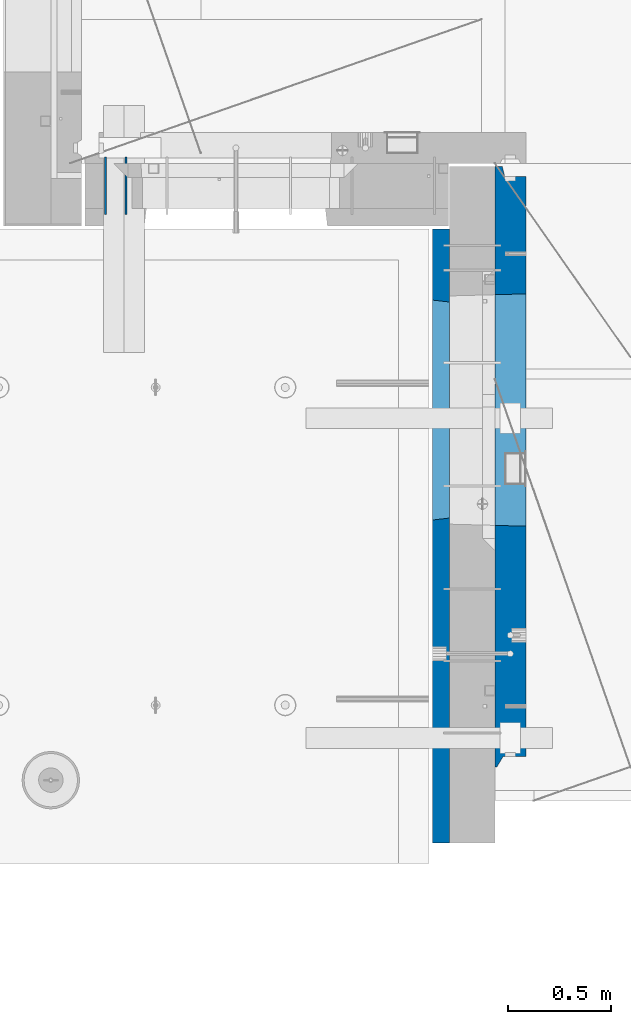
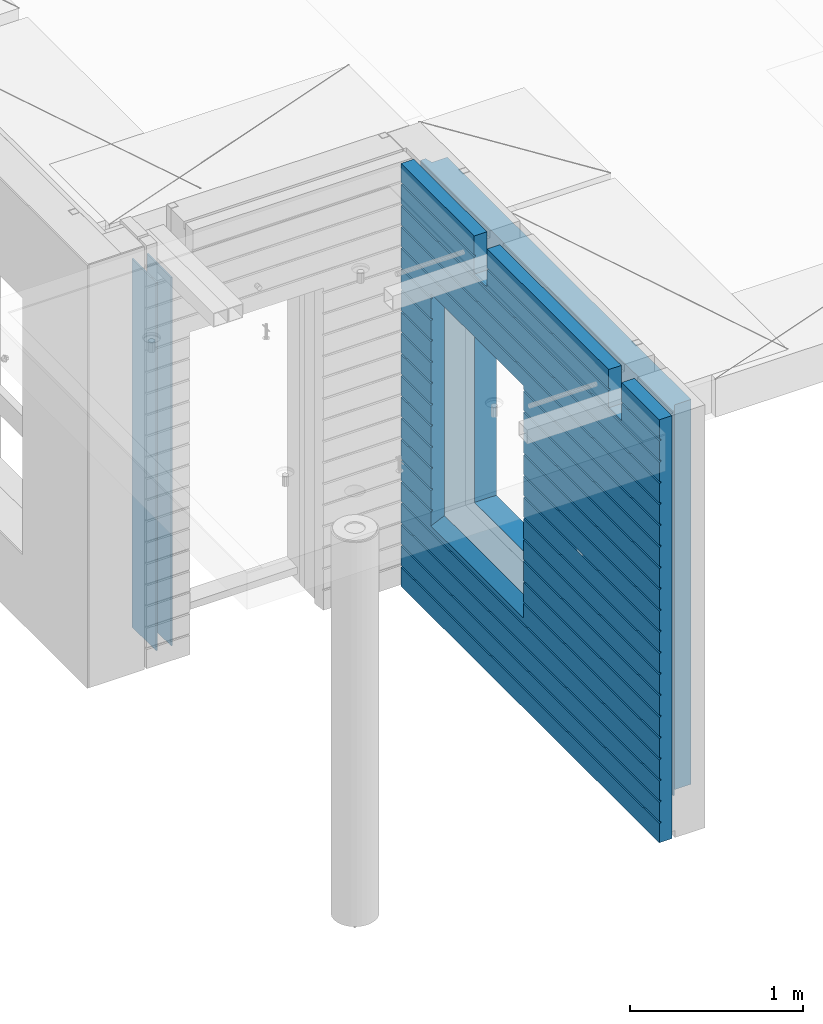
# One storey, part 193 of 309: 4 walls, 2 elements without a shape of their own.
"""IFC2X3 building model written with IfcOpenShell, lengths in millimetres."""

from ifc_helpers import new_model, si_unit, frame, origin_with_axes, place, context, subcontext, project, spatial, faceted_brep, material, type_object, element, aggregate, save


model = new_model("IFC2X3")

# Units and contexts
model_context = context("Model", 3, precision=1e-05, world=origin_with_axes())
body_context = subcontext(model_context, "Body", "Model", "MODEL_VIEW")
ifc_project = project(units=[si_unit("LENGTHUNIT", "METRE", prefix="MILLI"), si_unit("AREAUNIT", "SQUARE_METRE"), si_unit("VOLUMEUNIT", "CUBIC_METRE"), si_unit("MASSUNIT", "GRAM", prefix="KILO"), si_unit("TIMEUNIT", "SECOND"), si_unit("PLANEANGLEUNIT", "RADIAN"), si_unit("SOLIDANGLEUNIT", "STERADIAN"), si_unit("THERMODYNAMICTEMPERATUREUNIT", "DEGREE_CELSIUS"), si_unit("LUMINOUSINTENSITYUNIT", "LUMEN")], contexts=[model_context])

# Site, building, storey
site_placement = place(None, origin_with_axes())
site = spatial("IfcSite", under=ifc_project, at=site_placement, CompositionType="ELEMENT")
building_placement = place(site_placement, origin_with_axes())
building = spatial("IfcBuilding", under=site, at=building_placement, CompositionType="ELEMENT")
storey_placement = place(building_placement, origin_with_axes())
storey = spatial("IfcBuildingStorey", under=building, at=storey_placement, Name="7", CompositionType="ELEMENT", Elevation=0.0)

# Assembly, walls
assembly_1_placement = place(storey_placement, origin_with_axes())
assembly_1 = element("IfcElementAssembly", 1, at=assembly_1_placement, inside=storey, AssemblyPlace="NOTDEFINED", PredefinedType="REINFORCEMENT_UNIT")
ifc_material_1 = material(Name="Undefined")
wall_type_1 = type_object("IfcWallType", PredefinedType="NOTDEFINED")
wall_1_placement = place(assembly_1_placement, frame((8215.0, 10980.0, 101115.0), z_axis=(0.0, 0.0, 1.0), x_axis=(0.0, -1.0, 0.0)))
wall_1 = element("IfcWall", 2, at=wall_1_placement, type_object=wall_type_1, material=ifc_material_1, Name="(PD)", context=body_context, shape_type="Brep", body=[
    faceted_brep([(0.0, 5.0, -1300.0), (0.0, 5.0, 1300.0), (280.0, 5.0, 1300.0), (280.0, 5.0, -1300.0), (0.0, -5.0, 1300.0), (280.0, -5.0, 1300.0), (0.0, -5.0, -1300.0), (280.0, -5.0, -1300.0)], [[[0, 1, 2, 3]], [[1, 4, 5, 2]], [[4, 6, 7, 5]], [[6, 0, 3, 7]], [[5, 7, 3, 2]], [[6, 4, 1, 0]]]),
])
wall_2_placement = place(assembly_1_placement, frame((8115.0, 10980.0, 101115.0), z_axis=(0.0, 0.0, 1.0), x_axis=(0.0, -1.0, 0.0)))
wall_2 = element("IfcWall", 3, at=wall_2_placement, type_object=wall_type_1, material=ifc_material_1, Name="(PD)", context=body_context, shape_type="Brep", body=[
    faceted_brep([(0.0, 5.0, -1300.0), (0.0, 5.0, 1300.0), (280.0, 5.0, 1300.0), (280.0, 5.0, -1300.0), (0.0, -5.0, 1300.0), (280.0, -5.0, 1300.0), (0.0, -5.0, -1300.0), (280.0, -5.0, -1300.0)], [[[0, 1, 2, 3]], [[1, 4, 5, 2]], [[4, 6, 7, 5]], [[6, 0, 3, 7]], [[5, 7, 3, 2]], [[6, 4, 1, 0]]]),
])
aggregate(assembly_1, [wall_1, wall_2])

assembly_2_placement = place(storey_placement, origin_with_axes())
assembly_2 = element("IfcElementAssembly", 4, at=assembly_2_placement, inside=storey, AssemblyPlace="NOTDEFINED", PredefinedType="REINFORCEMENT_UNIT")
ifc_material_2 = material(Name="CONCRETE/C30/37")
wall_type_2 = type_object("IfcWallType", PredefinedType="NOTDEFINED")
wall_3_placement = place(assembly_2_placement, frame((9747.5, 8000.0, 101247.5), z_axis=(0.0, 0.0, 1.0), x_axis=(0.0, 1.0, 0.0)))
wall_3 = element("IfcWall", 5, at=wall_3_placement, type_object=wall_type_2, material=ifc_material_2, context=body_context, shape_type="Brep", body=[
    faceted_brep([(-355.0, 32.4999992499324, 1344.99999999921), (-355.0, 32.4999991119385, 1355.00000040044), (79.9999999999982, 32.4999991119385, 1355.00000040044), (79.9999999999982, 32.4999992499324, 1344.99999999921), (-355.0, 42.5, 1342.99999994476), (79.9999999999982, 42.5, 1342.99999994476), (2630.0, 32.4999991119385, 1355.00000040044), (2630.0, 32.4999992499324, 1344.99999999921), (1785.0, 32.4999992499324, 1344.99999999921), (1785.0, 32.4999991119385, 1355.00000040044), (2630.0, 42.5, 1356.99999988925), (1785.0, 42.5, 1356.99999988925), (2630.0, 42.5, 1492.5), (1785.0, 42.5, 1492.5), (2630.0, -42.5, 1492.5), (1785.0, -42.5, 1492.5), (-355.0, -42.5, -1492.5), (-355.0, 42.5, -1492.5), (2630.0, 42.5, -1492.5), (2630.0, -42.5, -1492.5), (-355.0, 42.5, -1357.00000005524), (2630.0, 42.5, -1357.00000005524), (-355.0, 32.4999992506928, -1355.0000000008), (2630.0, 32.4999992506928, -1355.0000000008), (-355.0, 32.4999991126915, -1344.99999959957), (2630.0, 32.4999991126915, -1344.99999959957), (-355.0, 42.5, -1343.00000011075), (2630.0, 42.5, -1343.00000011075), (-355.0, 42.5, -1207.00000005524), (2630.0, 42.5, -1207.00000005524), (-355.0, 32.4999992506928, -1205.0000000008), (2630.0, 32.4999992506928, -1205.0000000008), (-355.0, 32.4999991126915, -1194.99999959957), (2630.0, 32.4999991126915, -1194.99999959957), (-355.0, 42.5, -1193.00000011075), (2630.0, 42.5, -1193.00000011075), (-355.0, 42.5, -1057.00000005525), (2630.0, 42.5, -1057.00000005525), (-355.0, 32.4999992512294, -1055.00000000081), (2630.0, 32.4999992512294, -1055.00000000081), (-355.0, 32.4999991132281, -1044.99999959959), (2630.0, 32.4999991132281, -1044.99999959959), (-355.0, 42.5, -1043.00000011077), (2630.0, 42.5, -1043.00000011077), (-355.0, 42.5, -907.000000055225), (2630.0, 42.5, -907.000000055225), (-355.000000000001, 32.4999992517678, -905.000000000786), (2630.0, 32.4999992517678, -905.000000000786), (-355.000000000001, 32.4999991137665, -894.99999959956), (2630.0, 32.4999991137665, -894.99999959956), (-355.0, 42.5, -893.00000011074), (2630.0, 42.5, -893.00000011074), (2630.0, 42.5, -307.000000055239), (2630.0, 32.4999992538942, -305.0000000008), (2630.0, 32.4999991158911, -294.999999599575), (2630.0, 42.5, -293.000000110755), (2630.0, 42.5, -157.000000055254), (2630.0, 32.4999992544235, -155.000000000815), (2630.0, 32.4999991164223, -144.99999959959), (2630.0, 42.5, -143.000000110769), (2630.0, 42.5, -7.00000005523907), (2630.0, 32.4999992500489, -5.0000000007858), (2630.0, 32.4999991120549, 5.0000004004396), (2630.0, 42.5, 6.99999988924537), (2630.0, 42.5, 142.999999944761), (2630.0, 32.4999992500361, 144.999999999214), (2630.0, 32.4999991120421, 155.00000040044), (2630.0, 42.5, 156.999999889245), (2630.0, 42.5, 292.999999944761), (2630.0, 32.4999992500234, 294.999999999214), (2630.0, 32.4999991120294, 305.00000040044), (2630.0, 42.5, 306.999999889245), (2630.0, 42.5, 442.999999944761), (2630.0, 32.4999992500107, 444.999999999214), (2630.0, 32.4999991120167, 455.00000040044), (2630.0, 42.5, 456.999999889245), (2630.0, 42.5, 592.999999944761), (2630.0, 32.4999992499979, 594.999999999214), (2630.0, 32.4999991120039, 605.00000040044), (2630.0, 42.5, 606.999999889245), (2630.0, 42.5, 742.999999944761), (2630.0, 32.4999992499852, 744.999999999214), (2630.0, 32.4999991119912, 755.00000040044), (2630.0, 42.5, 756.999999889245), (2630.0, 42.5, 892.999999944761), (2630.0, 32.4999992499725, 894.999999999214), (2630.0, 32.4999991119785, 905.00000040044), (2630.0, 42.5, 906.999999889245), (2630.0, 42.5, 1042.99999994476), (2630.0, 32.4999992499597, 1044.99999999921), (2630.0, 32.4999991119657, 1055.00000040044), (2630.0, 42.5, 1056.99999988925), (2630.0, 42.5, 1192.99999994476), (2630.0, 32.499999249947, 1194.99999999921), (2630.0, 32.499999111953, 1205.00000040044), (2630.0, 42.5, 1206.99999988925), (2630.0, 42.5, 1342.99999994476), (2630.0, 42.5, -757.000000055225), (2630.0, 32.4999992522953, -755.000000000786), (2630.0, 32.499999114294, -744.99999959956), (2630.0, 42.5, -743.00000011074), (2630.0, 42.5, -607.000000055225), (2630.0, 32.4999992522953, -605.000000000786), (2630.0, 32.499999114294, -594.99999959956), (2630.0, 42.5, -593.00000011074), (2630.0, 42.5, -457.000000055225), (2630.0, 32.4999992522953, -455.000000000786), (2630.0, 32.499999114294, -444.99999959956), (2630.0, 42.5, -443.00000011074), (1785.0, 42.5, 1342.99999994476), (1785.0, 42.5, 1222.5), (1785.0, -42.5, 1222.5), (1635.0, 42.5, 1222.5), (1635.0, -42.5, 1222.5), (1635.0, -42.5, 1492.5), (1635.0, 42.5, 1492.5), (229.999999999998, 42.5, 1492.5), (229.999999999998, -42.5, 1492.5), (1635.0, 32.4999991119385, 1355.00000040044), (1635.0, 32.4999992499324, 1344.99999999921), (229.999999999998, 32.4999992499324, 1344.99999999921), (229.999999999998, 32.4999991119385, 1355.00000040044), (1635.0, 42.5, 1356.99999988925), (229.999999999998, 42.5, 1356.99999988925), (1635.0, 42.5, 1342.99999994476), (229.999999999998, 42.5, 1342.99999994476), (229.999999999998, -42.5, 1222.5), (229.999999999998, 42.5, 1222.5), (79.9999999999982, 42.5, 1222.5), (79.9999999999982, -42.5, 1222.5), (-355.0, 42.5, 1206.99999988925), (-355.0, 32.499999111953, 1205.00000040044), (-355.0, 32.499999249947, 1194.99999999921), (-355.0, 42.5, 1192.99999994476), (-355.0, 42.5, 1056.99999988925), (-355.0, 32.4999991119657, 1055.00000040044), (-355.0, 32.4999992499597, 1044.99999999921), (-355.0, 42.5, 1042.99999994476), (-355.0, 42.5, 906.999999889245), (-354.999999999999, 32.4999991119785, 905.00000040044), (-354.999999999999, 32.4999992499725, 894.999999999214), (-355.0, 42.5, 892.999999944761), (-355.0, 42.5, -457.000000055225), (-355.0, 42.5, -593.00000011074), (-354.999999999998, 32.499999114294, -594.99999959956), (-354.999999999998, 32.4999992522953, -605.000000000786), (-355.0, 42.5, -607.000000055225), (-355.0, 42.5, -743.00000011074), (-355.0, 32.499999114294, -744.99999959956), (-355.0, 32.4999992522953, -755.000000000786), (-355.0, 42.5, -757.000000055225), (-355.0, -42.5, 1492.5), (-355.0, 42.5, 1492.5), (-355.0, 42.5, 1356.99999988925), (-355.0, 42.5, 756.999999889245), (-354.999999999999, 32.4999991119912, 755.00000040044), (-354.999999999999, 32.4999992499852, 744.999999999214), (-355.0, 42.5, 742.999999944761), (-355.0, 42.5, 606.999999889245), (-355.0, 32.4999991120039, 605.00000040044), (-355.0, 32.4999992499979, 594.999999999214), (-355.0, 42.5, 592.999999944761), (-355.0, 42.5, 456.999999889245), (-355.0, 32.4999991120167, 455.00000040044), (-355.0, 32.4999992500107, 444.999999999214), (-355.0, 42.5, 442.999999944761), (-355.0, 42.5, 306.999999889245), (-355.0, 32.4999991120294, 305.00000040044), (-355.0, 32.4999992500234, 294.999999999214), (-355.0, 42.5, 292.999999944761), (-355.0, 42.5, 156.999999889245), (-355.0, 32.4999991120421, 155.00000040044), (-355.0, 32.4999992500361, 144.999999999214), (-355.0, 42.5, 142.999999944761), (-355.0, 42.5, 6.99999988924537), (-355.0, 32.4999991120549, 5.0000004004396), (-355.0, 32.4999992500489, -5.0000000007858), (-355.0, 42.5, -7.00000005523907), (-355.0, 42.5, -143.000000110769), (-354.999999999999, 32.4999991164223, -144.99999959959), (-354.999999999999, 32.4999992544235, -155.000000000815), (-355.0, 42.5, -157.000000055254), (-355.0, 42.5, -293.000000110755), (-355.0, 32.4999991158911, -294.999999599575), (-355.0, 32.4999992538942, -305.0000000008), (-355.0, 42.5, -307.000000055239), (-355.0, 42.5, -443.00000011074), (-355.000000000001, 32.499999114294, -444.99999959956), (-355.000000000001, 32.4999992522953, -455.000000000786), (1215.00311728789, 42.5, 756.999999889245), (1216.1795879806, 32.4999991119912, 755.00000040044), (1216.17958796436, 32.4999992499852, 744.999999999214), (1215.00311728789, 42.5, 742.999999944761), (1215.00311728789, 42.5, 606.999999889245), (1216.1795879806, 32.4999991120039, 605.00000040044), (1216.17958796436, 32.4999992499979, 594.999999999214), (1215.00311728789, 42.5, 592.999999944761), (1215.00311728789, 42.5, 456.999999889245), (1216.17958798059, 32.4999991120167, 455.00000040044), (1216.17958796436, 32.4999992500107, 444.999999999214), (1215.00311728789, 42.5, 442.999999944761), (1215.00311728789, 42.5, 306.999999889245), (1216.17958798059, 32.4999991120294, 305.00000040044), (1216.17958796436, 32.4999992500234, 294.999999999214), (1215.00311728789, 42.5, 292.999999944761), (1215.00311728789, 42.5, 156.999999889245), (1216.17958798059, 32.4999991120421, 155.00000040044), (1216.17958796436, 32.4999992500361, 144.999999999214), (1215.00311728789, 42.5, 142.999999944761), (1215.00311728789, 42.5, 6.99999988924537), (1216.17958798059, 32.4999991120549, 5.0000004004396), (1216.17958796435, 32.4999992500489, -5.0000000007858), (1215.00311728789, 42.5, -7.00000005523907), (1215.00311728789, 42.5, -143.000000110769), (1216.17958798008, 32.4999991164223, -144.99999959959), (1216.17958796384, 32.4999992544235, -155.000000000815), (1215.00311728789, 42.5, -157.000000055254), (1215.00311728789, 42.5, -293.000000110755), (1216.17958798014, 32.4999991158911, -294.999999599575), (1216.1795879639, 32.4999992538942, -305.0000000008), (1215.00311728789, 42.5, -307.000000055239), (1215.00311728789, 42.5, -443.00000011074), (1216.17958798033, 32.499999114294, -444.99999959956), (1216.17958796409, 32.4999992522953, -455.000000000786), (1215.00311728789, 42.5, -457.000000055225), (1215.00311728789, 42.5, -593.00000011074), (1216.17958798033, 32.499999114294, -594.99999959956), (1216.17958796409, 32.4999992522953, -605.000000000786), (1215.00311728789, 42.5, -607.000000055225), (1215.00311728789, 42.5, -743.00000011074), (1216.17958798033, 32.499999114294, -744.99999959956), (1216.17958796409, 32.4999992522953, -755.000000000786), (1215.00311728789, 42.5, -757.000000055225), (1215.00311728789, 42.5, -857.5), (2285.00311728789, 42.5, -857.5), (2285.00311728789, 42.5, -757.000000055225), (2283.82664661169, 32.4999992522953, -755.000000000786), (2283.82664659545, 32.499999114294, -744.99999959956), (2285.00311728789, 42.5, -743.00000011074), (2285.00311728789, 42.5, -607.000000055225), (2283.82664661169, 32.4999992522953, -605.000000000786), (2283.82664659545, 32.499999114294, -594.99999959956), (2285.00311728789, 42.5, -593.00000011074), (2285.00311728789, 42.5, -457.000000055225), (2283.82664661169, 32.4999992522953, -455.000000000786), (2283.82664659545, 32.499999114294, -444.99999959956), (2285.00311728789, 42.5, -443.00000011074), (2285.00311728789, 42.5, -307.000000055239), (2283.82664661188, 32.4999992538942, -305.0000000008), (2283.82664659564, 32.4999991158911, -294.999999599575), (2285.00311728789, 42.5, -293.000000110755), (2285.00311728789, 42.5, -157.000000055254), (2283.82664661194, 32.4999992544235, -155.000000000815), (2283.82664659571, 32.4999991164223, -144.99999959959), (2285.00311728789, 42.5, -143.000000110769), (2285.00311728789, 42.5, -7.00000005523907), (2283.82664661143, 32.4999992500489, -5.0000000007858), (2283.82664659519, 32.4999991120549, 5.0000004004396), (2285.00311728789, 42.5, 6.99999988924537), (2285.00311728789, 42.5, 142.999999944761), (2283.82664661143, 32.4999992500361, 144.999999999214), (2283.82664659519, 32.4999991120421, 155.00000040044), (2285.00311728789, 42.5, 156.999999889245), (2285.00311728789, 42.5, 292.999999944761), (2283.82664661142, 32.4999992500234, 294.999999999214), (2283.82664659519, 32.4999991120294, 305.00000040044), (2285.00311728789, 42.5, 306.999999889245), (2285.00311728789, 42.5, 442.999999944761), (2283.82664661142, 32.4999992500107, 444.999999999214), (2283.82664659519, 32.4999991120167, 455.00000040044), (2285.00311728789, 42.5, 456.999999889245), (2285.00311728789, 42.5, 592.999999944761), (2283.82664661142, 32.4999992499979, 594.999999999214), (2283.82664659519, 32.4999991120039, 605.00000040044), (2285.00311728789, 42.5, 606.999999889245), (2285.00311728789, 42.5, 742.999999944761), (2283.82664661142, 32.4999992499852, 744.999999999214), (2283.82664659518, 32.4999991119912, 755.00000040044), (2285.00311728789, 42.5, 756.999999889245), (1225.00311728789, 42.5, 782.5), (1215.00311728789, 42.5, 782.5), (2285.00311728789, 42.5, 782.5), (2275.00311728789, 42.5, 782.5), (1225.00311728789, -42.5, 787.5), (2275.00311728789, -42.5, 787.5), (1225.00311728789, -42.5, 782.5), (1225.00311728789, -42.5, -807.5), (2275.00311728789, -42.5, -807.5), (2275.00311728789, -42.5, 782.5), (79.9999999999982, -42.5, 1492.5), (79.9999999999982, 42.5, 1492.5), (79.9999999999982, 42.5, 1356.99999988925)], [[[0, 1, 2, 3]], [[4, 0, 3, 5]], [[6, 7, 8, 9]], [[10, 6, 9, 11]], [[12, 10, 11, 13]], [[14, 12, 13, 15]], [[16, 17, 18, 19]], [[18, 17, 20, 21]], [[21, 20, 22, 23]], [[23, 22, 24, 25]], [[25, 24, 26, 27]], [[28, 29, 27, 26]], [[29, 28, 30, 31]], [[31, 30, 32, 33]], [[33, 32, 34, 35]], [[35, 34, 36, 37]], [[37, 36, 38, 39]], [[39, 38, 40, 41]], [[41, 40, 42, 43]], [[43, 42, 44, 45]], [[45, 44, 46, 47]], [[47, 46, 48, 49]], [[49, 48, 50, 51]], [[52, 53, 54, 55, 56, 57, 58, 59, 60, 61, 62, 63, 64, 65, 66, 67, 68, 69, 70, 71, 72, 73, 74, 75, 76, 77, 78, 79, 80, 81, 82, 83, 84, 85, 86, 87, 88, 89, 90, 91, 92, 93, 94, 95, 96, 7, 6, 10, 12, 14, 19, 18, 21, 23, 25, 27, 29, 31, 33, 35, 37, 39, 41, 43, 45, 47, 49, 51, 97, 98, 99, 100, 101, 102, 103, 104, 105, 106, 107, 108]], [[7, 96, 109, 8]], [[15, 13, 11, 9, 8, 109, 110, 111]], [[111, 110, 112, 113]], [[114, 115, 116, 117]], [[118, 119, 120, 121]], [[122, 118, 121, 123]], [[115, 122, 123, 116]], [[114, 113, 112, 124, 119, 118, 122, 115]], [[119, 124, 125, 120]], [[126, 127, 128, 129]], [[117, 116, 123, 121, 120, 125, 127, 126]], [[124, 112, 110, 109, 96, 95, 130, 4, 5, 128, 127, 125]], [[94, 131, 130, 95]], [[93, 132, 131, 94]], [[92, 133, 132, 93]], [[91, 134, 133, 92]], [[90, 135, 134, 91]], [[89, 136, 135, 90]], [[88, 137, 136, 89]], [[87, 138, 137, 88]], [[86, 139, 138, 87]], [[85, 140, 139, 86]], [[84, 141, 140, 85]], [[142, 143, 144, 145, 146, 147, 148, 149, 150, 50, 48, 46, 44, 42, 40, 38, 36, 34, 32, 30, 28, 26, 24, 22, 20, 17, 16, 151, 152, 153, 1, 0, 4, 130, 131, 132, 133, 134, 135, 136, 137, 138, 139, 140, 141, 154, 155, 156, 157, 158, 159, 160, 161, 162, 163, 164, 165, 166, 167, 168, 169, 170, 171, 172, 173, 174, 175, 176, 177, 178, 179, 180, 181, 182, 183, 184, 185, 186, 187, 188]], [[155, 154, 189, 190]], [[156, 155, 190, 191]], [[157, 156, 191, 192]], [[158, 157, 192, 193]], [[159, 158, 193, 194]], [[160, 159, 194, 195]], [[161, 160, 195, 196]], [[162, 161, 196, 197]], [[163, 162, 197, 198]], [[164, 163, 198, 199]], [[165, 164, 199, 200]], [[166, 165, 200, 201]], [[167, 166, 201, 202]], [[168, 167, 202, 203]], [[169, 168, 203, 204]], [[170, 169, 204, 205]], [[171, 170, 205, 206]], [[172, 171, 206, 207]], [[173, 172, 207, 208]], [[174, 173, 208, 209]], [[175, 174, 209, 210]], [[176, 175, 210, 211]], [[177, 176, 211, 212]], [[178, 177, 212, 213]], [[179, 178, 213, 214]], [[180, 179, 214, 215]], [[181, 180, 215, 216]], [[182, 181, 216, 217]], [[183, 182, 217, 218]], [[184, 183, 218, 219]], [[185, 184, 219, 220]], [[186, 185, 220, 221]], [[187, 186, 221, 222]], [[188, 187, 222, 223]], [[142, 188, 223, 224]], [[143, 142, 224, 225]], [[144, 143, 225, 226]], [[145, 144, 226, 227]], [[146, 145, 227, 228]], [[147, 146, 228, 229]], [[148, 147, 229, 230]], [[149, 148, 230, 231]], [[150, 149, 231, 232]], [[97, 51, 50, 150, 232, 233, 234, 235]], [[98, 97, 235, 236]], [[99, 98, 236, 237]], [[100, 99, 237, 238]], [[101, 100, 238, 239]], [[102, 101, 239, 240]], [[103, 102, 240, 241]], [[104, 103, 241, 242]], [[105, 104, 242, 243]], [[106, 105, 243, 244]], [[107, 106, 244, 245]], [[108, 107, 245, 246]], [[52, 108, 246, 247]], [[53, 52, 247, 248]], [[54, 53, 248, 249]], [[55, 54, 249, 250]], [[56, 55, 250, 251]], [[57, 56, 251, 252]], [[58, 57, 252, 253]], [[59, 58, 253, 254]], [[60, 59, 254, 255]], [[61, 60, 255, 256]], [[62, 61, 256, 257]], [[63, 62, 257, 258]], [[64, 63, 258, 259]], [[65, 64, 259, 260]], [[66, 65, 260, 261]], [[67, 66, 261, 262]], [[68, 67, 262, 263]], [[69, 68, 263, 264]], [[70, 69, 264, 265]], [[71, 70, 265, 266]], [[72, 71, 266, 267]], [[73, 72, 267, 268]], [[74, 73, 268, 269]], [[75, 74, 269, 270]], [[76, 75, 270, 271]], [[77, 76, 271, 272]], [[78, 77, 272, 273]], [[79, 78, 273, 274]], [[80, 79, 274, 275]], [[81, 80, 275, 276]], [[82, 81, 276, 277]], [[83, 82, 277, 278]], [[279, 280, 189, 154, 141, 84, 83, 278, 281, 282]], [[283, 280, 279, 282, 281, 284]], [[285, 286, 233, 232, 231, 230, 229, 228, 227, 226, 225, 224, 223, 222, 221, 220, 219, 218, 217, 216, 215, 214, 213, 212, 211, 210, 209, 208, 207, 206, 205, 204, 203, 202, 201, 200, 199, 198, 197, 196, 195, 194, 193, 192, 191, 190, 189, 280, 283]], [[287, 234, 233, 286]], [[288, 284, 281, 278, 277, 276, 275, 274, 273, 272, 271, 270, 269, 268, 267, 266, 265, 264, 263, 262, 261, 260, 259, 258, 257, 256, 255, 254, 253, 252, 251, 250, 249, 248, 247, 246, 245, 244, 243, 242, 241, 240, 239, 238, 237, 236, 235, 234, 287]], [[129, 289, 151, 16, 19, 14, 15, 111, 113, 114, 117, 126], [287, 286, 285, 283, 284, 288]], [[152, 151, 289, 290]], [[153, 152, 290, 291]], [[289, 129, 128, 5, 3, 2, 291, 290]], [[1, 153, 291, 2]]]),
])
ifc_material_3 = material(Name="CONCRETE/C25/30")
wall_type_3 = type_object("IfcWallType", PredefinedType="NOTDEFINED")
wall_4_placement = place(assembly_2_placement, frame((10085.0, 8000.0, 101112.5), z_axis=(0.0, 0.0, 1.0), x_axis=(0.0, 1.0, 0.0)))
wall_4 = element("IfcWall", 6, at=wall_4_placement, type_object=wall_type_3, material=ifc_material_3, context=body_context, shape_type="Brep", body=[
    faceted_brep([(2885.0, -75.0, 1357.5), (2885.0, -75.0, -1357.5), (2885.0, 27.0, -1357.5), (2885.0, 27.0, 1357.5), (2934.99999772087, 40.0, 1357.5), (2934.99999772087, 75.0, 1357.5), (15.0, 75.0, 1357.5), (15.0, 65.0, 1357.5), (65.0, 35.0, 1357.5), (65.0, -75.0, 1357.5), (15.0, 75.0, -1357.5), (15.0, 65.0, -1357.5), (65.0, 35.0, -1357.5), (65.0, -75.0, -1357.5), (1380.0, -75.0, -1357.5), (1380.0, -74.9999999938009, -1207.49999999684), (1550.0, -74.9999999938009, -1207.49999999684), (1550.0, -75.0, -1357.5), (1185.00311728789, -75.0000000030959, -682.5), (1185.00311728789, -75.0000000030959, 952.5), (2315.00311728789, -75.0000000030959, 952.5), (2315.00311728789, -75.0000000030959, -682.5), (1380.0, -72.9999999938009, -1207.49999999684), (1550.0, -72.9999999938009, -1207.49999999684), (1380.0, -72.9999999938009, -1357.4999999999), (1550.0, -72.9999999938009, -1357.4999999999), (2934.99999772087, 75.0, -1357.5), (2934.99999772087, 40.0, -1357.5), (1189.05717134203, 75.0, -678.445945945859), (2310.94906323375, 75.0, -678.445945945859), (2310.94906323375, 75.0, 948.445945945859), (1189.05717134203, 75.0, 948.445945945859)], [[[0, 1, 2, 3]], [[4, 5, 6, 7, 8, 9, 0, 3]], [[6, 10, 11, 7]], [[7, 11, 12, 8]], [[9, 8, 12, 13]], [[1, 0, 9, 13, 14, 15, 16, 17], [18, 19, 20, 21]], [[15, 22, 23, 16]], [[14, 24, 22, 15]], [[25, 23, 22, 24]], [[16, 23, 25, 17]], [[24, 14, 13, 12, 11, 10, 26, 27, 2, 1, 17, 25]], [[3, 2, 27, 4]], [[26, 5, 4, 27]], [[10, 6, 5, 26], [28, 29, 30, 31]], [[20, 30, 29, 21]], [[19, 31, 30, 20]], [[18, 28, 31, 19]], [[21, 29, 28, 18]]]),
])
aggregate(assembly_2, [wall_3, wall_4])

save(model, "model.ifc")
